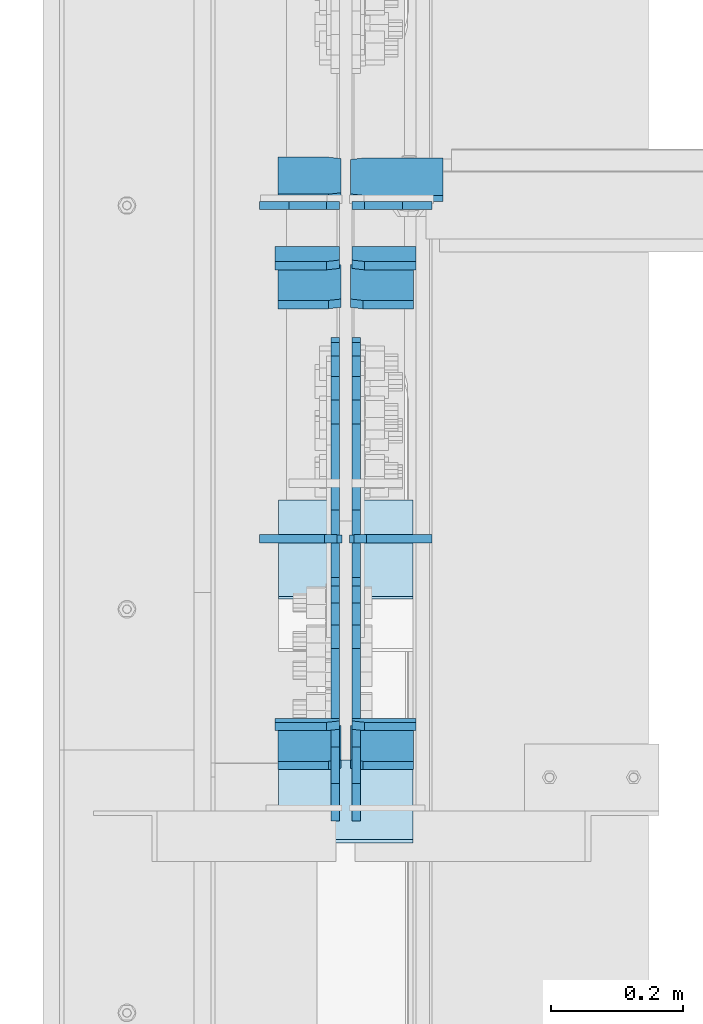
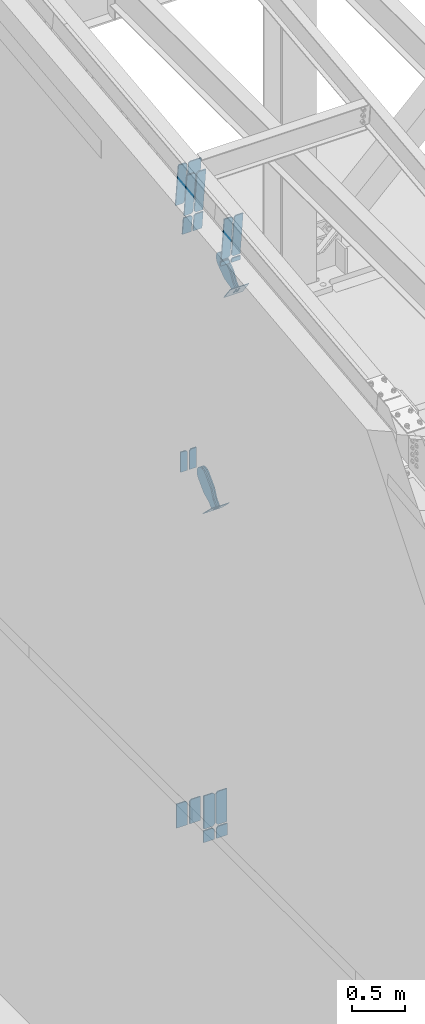
# One storey, part 992 of 1179: 24 plates, 9 elements without a shape of their own.
"""IFC2X3 building model written with IfcOpenShell, lengths in millimetres."""

from ifc_helpers import new_model, si_unit, frame, origin_with_axes, place, context, subcontext, project, spatial, faceted_brep, material, type_object, element, aggregate, save


model = new_model("IFC2X3")

# Units and contexts
model_context = context("Model", 3, precision=1e-05, world=origin_with_axes())
body_context = subcontext(model_context, "Body", "Model", "MODEL_VIEW")
ifc_project = project(units=[si_unit("LENGTHUNIT", "METRE", prefix="MILLI"), si_unit("AREAUNIT", "SQUARE_METRE"), si_unit("VOLUMEUNIT", "CUBIC_METRE"), si_unit("MASSUNIT", "GRAM", prefix="KILO"), si_unit("TIMEUNIT", "SECOND"), si_unit("PLANEANGLEUNIT", "RADIAN"), si_unit("SOLIDANGLEUNIT", "STERADIAN"), si_unit("THERMODYNAMICTEMPERATUREUNIT", "DEGREE_CELSIUS"), si_unit("LUMINOUSINTENSITYUNIT", "LUMEN")], contexts=[model_context])

# Site, building, storey
site_placement = place(None, origin_with_axes())
site = spatial("IfcSite", under=ifc_project, at=site_placement, CompositionType="ELEMENT")
building_placement = place(site_placement, origin_with_axes())
building = spatial("IfcBuilding", under=site, at=building_placement, Name="Undefined", CompositionType="ELEMENT")
storey_placement = place(building_placement, origin_with_axes())
storey = spatial("IfcBuildingStorey", under=building, at=storey_placement, Name="Undefined", CompositionType="ELEMENT", Elevation=0.0)

# Assembly, plates
assembly_1_placement = place(storey_placement, origin_with_axes())
assembly_1 = element("IfcElementAssembly", 1, at=assembly_1_placement, inside=storey, Name="BEAM", AssemblyPlace="NOTDEFINED", PredefinedType="RIGID_FRAME")
ifc_material_1 = material(Name="STEEL/A572-GR.50")
plate_type_1 = type_object("IfcPlateType", PredefinedType="NOTDEFINED")
plate_1_placement = place(assembly_1_placement, frame((534.193750000002, 15260.6053029208, 10444.0992973498), z_axis=(0.0, -0.112284087038017, 0.993676146336441), x_axis=(-1.0, 0.0, 0.0)))
plate_1 = element("IfcPlate", 2, at=plate_1_placement, type_object=plate_type_1, material=ifc_material_1, Name="PLATE", context=body_context, shape_type="Brep", body=[
    faceted_brep([(0.0, -6.34999999999854, 0.0), (0.0, -6.35000000019863, 498.474999998592), (0.0, 6.34999999979118, 498.474999998596), (0.0, 6.34999999999854, 0.0), (76.2000007629395, -6.35000000019863, 498.474999998592), (76.2000007629395, 6.34999999979118, 498.474999998596), (95.25, -6.350000000195, 479.425000761541), (95.25, 6.34999999980209, 479.425000761548), (95.25, -6.35000000000946, 19.0499992370496), (95.25, 6.34999999998399, 19.0499992370533), (76.2000007629395, -6.35000000000218, 0.0), (76.2000007629395, 6.34999999999491, 3.63797880709171e-12)], [[[0, 1, 2, 3]], [[1, 4, 5, 2]], [[4, 6, 7, 5]], [[6, 8, 9, 7]], [[8, 10, 11, 9]], [[10, 0, 3, 11]], [[5, 7, 9, 11, 3, 2]], [[10, 8, 6, 4, 1, 0]]]),
])
plate_2_placement = place(assembly_1_placement, frame((424.656250000002, 15260.6053029208, 10444.0992973498), z_axis=(0.0, -0.112284087038017, 0.993676146336441), x_axis=(-1.0, 0.0, 0.0)))
plate_2 = element("IfcPlate", 3, at=plate_2_placement, type_object=plate_type_1, material=ifc_material_1, Name="PLATE", context=body_context, shape_type="Brep", body=[
    faceted_brep([(0.0, -6.35000000000036, 19.0499999999993), (0.0, -6.350000000195, 479.425000761541), (0.0, 6.34999999980209, 479.425000761548), (0.0, 6.35000000000036, 19.0499999999993), (19.0499992370605, -6.35000000019863, 498.474999998592), (19.0499992370605, 6.34999999979118, 498.474999998596), (95.25, -6.349999999793, 498.474999998598), (95.25, 6.35000000020045, 498.474999998592), (95.25, -6.34999999999309, 1.81898940354586e-12), (95.25, 6.34999999999854, -1.81898940354586e-12), (19.0500000000002, -6.35000000000036, 0.0), (19.0500000000002, 6.35000000000036, 0.0)], [[[0, 1, 2, 3]], [[1, 4, 5, 2]], [[4, 6, 7, 5]], [[6, 8, 9, 7]], [[8, 10, 11, 9]], [[3, 11, 10, 0]], [[5, 7, 9, 11, 3, 2]], [[10, 8, 6, 4, 1, 0]]]),
])
plate_3_placement = place(assembly_1_placement, frame((534.193750000002, 14564.7196361651, 10365.4651396694), z_axis=(0.0, -0.112284087038017, 0.993676146336441), x_axis=(-1.0, 0.0, 0.0)))
plate_3 = element("IfcPlate", 4, at=plate_3_placement, type_object=plate_type_1, material=ifc_material_1, Name="PLATE", context=body_context, shape_type="Brep", body=[
    faceted_brep([(0.0, -6.34999999999854, 0.0), (0.0, -6.35000000019863, 498.474999998592), (0.0, 6.34999999979118, 498.474999998596), (0.0, 6.34999999999854, 0.0), (76.2000007629395, -6.35000000019863, 498.474999998592), (76.2000007629395, 6.34999999979118, 498.474999998596), (95.25, -6.350000000195, 479.425000761541), (95.25, 6.34999999980209, 479.425000761548), (95.25, -6.35000000000946, 19.0499992370496), (95.25, 6.34999999998399, 19.0499992370533), (76.2000007629395, -6.35000000000218, 0.0), (76.2000007629395, 6.34999999999491, 3.63797880709171e-12)], [[[0, 1, 2, 3]], [[1, 4, 5, 2]], [[4, 6, 7, 5]], [[6, 8, 9, 7]], [[8, 10, 11, 9]], [[10, 0, 3, 11]], [[5, 7, 9, 11, 3, 2]], [[10, 8, 6, 4, 1, 0]]]),
])
plate_4_placement = place(assembly_1_placement, frame((424.656250000002, 14564.7196361651, 10365.4651396694), z_axis=(0.0, -0.112284087038017, 0.993676146336441), x_axis=(-1.0, 0.0, 0.0)))
plate_4 = element("IfcPlate", 5, at=plate_4_placement, type_object=plate_type_1, material=ifc_material_1, Name="PLATE", context=body_context, shape_type="Brep", body=[
    faceted_brep([(0.0, -6.35000000000036, 19.0499999999993), (0.0, -6.350000000195, 479.425000761541), (0.0, 6.34999999980209, 479.425000761548), (0.0, 6.35000000000036, 19.0499999999993), (19.0499992370605, -6.35000000019863, 498.474999998592), (19.0499992370605, 6.34999999979118, 498.474999998596), (95.25, -6.349999999793, 498.474999998598), (95.25, 6.35000000020045, 498.474999998592), (95.25, -6.34999999999309, 1.81898940354586e-12), (95.25, 6.34999999999854, -1.81898940354586e-12), (19.0500000000002, -6.35000000000036, 0.0), (19.0500000000002, 6.35000000000036, 0.0)], [[[0, 1, 2, 3]], [[1, 4, 5, 2]], [[4, 6, 7, 5]], [[6, 8, 9, 7]], [[8, 10, 11, 9]], [[3, 11, 10, 0]], [[5, 7, 9, 11, 3, 2]], [[10, 8, 6, 4, 1, 0]]]),
])
ifc_material_2 = material(Name="STEEL/A36")
plate_5_placement = place(assembly_1_placement, frame((424.656250000002, 15421.0194659439, 10462.2258850809), z_axis=(0.0, -0.112284087038017, 0.993676146336441), x_axis=(-1.0, 0.0, 0.0)))
plate_5 = element("IfcPlate", 6, at=plate_5_placement, type_object=plate_type_1, material=ifc_material_2, Name="PLATE", context=body_context, shape_type="Brep", body=[
    faceted_brep([(0.0, -6.35000000000036, 19.0499999999993), (0.0, -6.350000000195, 479.425000761541), (0.0, 6.34999999980209, 479.425000761548), (0.0, 6.35000000000036, 19.0499999999993), (19.0499992370605, -6.35000000019863, 498.474999998592), (19.0499992370605, 6.34999999979118, 498.474999998596), (95.25, -6.349999999793, 498.474999998598), (95.25, 6.35000000020045, 498.474999998592), (95.25, -6.34999999999309, 1.81898940354586e-12), (95.25, 6.34999999999854, -1.81898940354586e-12), (19.0500000000002, -6.35000000000036, 0.0), (19.0500000000002, 6.35000000000036, 0.0)], [[[0, 1, 2, 3]], [[1, 4, 5, 2]], [[4, 6, 7, 5]], [[6, 8, 9, 7]], [[8, 10, 11, 9]], [[3, 11, 10, 0]], [[5, 7, 9, 11, 3, 2]], [[10, 8, 6, 4, 1, 0]]]),
])

assembly_2_placement = place(storey_placement, origin_with_axes())
assembly_2 = element("IfcElementAssembly", 7, at=assembly_2_placement, inside=storey, Name="BEAM", AssemblyPlace="NOTDEFINED", PredefinedType="RIGID_FRAME")
plate_type_2 = type_object("IfcPlateType", PredefinedType="NOTDEFINED")
plate_6_placement = place(assembly_2_placement, frame((558.006250000002, 14850.7648431904, 3703.6375), z_axis=(0.0, 0.0, 1.0), x_axis=(-1.0, 0.0, 0.0)))
plate_6 = element("IfcPlate", 8, at=plate_6_placement, type_object=plate_type_2, material=ifc_material_1, Name="PLATE", context=body_context, shape_type="Brep", body=[
    faceted_brep([(0.0, -6.34999999999854, 0.0), (0.0, -6.35000000000036, 377.825012207031), (0.0, 6.35000000000036, 377.825012207031), (0.0, 6.34999999999854, 0.0), (98.4250011444092, -6.35000000000036, 377.825012207031), (98.4250011444092, 6.35000000000036, 377.825012207031), (120.650001525879, -6.35000000000036, 355.600011825562), (120.650001525879, 6.35000000000036, 355.600011825562), (120.650001525879, -6.35000000000036, 22.2250003814697), (120.650001525879, 6.35000000000036, 22.2250003814697), (98.4250011444092, -6.35000000000036, 0.0), (98.4250011444092, 6.35000000000036, 0.0)], [[[0, 1, 2, 3]], [[1, 4, 5, 2]], [[4, 6, 7, 5]], [[6, 8, 9, 7]], [[8, 10, 11, 9]], [[10, 0, 3, 11]], [[5, 7, 9, 11, 3, 2]], [[10, 8, 6, 4, 1, 0]]]),
])
plate_7_placement = place(assembly_2_placement, frame((426.243750000002, 14850.7648431904, 3703.6375), z_axis=(0.0, 0.0, 1.0), x_axis=(-1.0, 0.0, 0.0)))
plate_7 = element("IfcPlate", 9, at=plate_7_placement, type_object=plate_type_2, material=ifc_material_1, Name="PLATE", context=body_context, shape_type="Brep", body=[
    faceted_brep([(0.0, -6.34999999999854, 22.2250003814697), (0.0, -6.34999999999854, 355.600011825562), (0.0, 6.34999999999854, 355.600011825562), (0.0, 6.34999999999854, 22.2250003814697), (22.2250003814697, -6.34999999999854, 377.825012207031), (22.2250003814697, 6.34999999999854, 377.825012207031), (120.650001525879, -6.34999999999854, 377.825012207031), (120.650001525879, 6.34999999999854, 377.825012207031), (120.650001525879, -6.34999999999854, 0.0), (120.650001525879, 6.34999999999854, 0.0), (22.2250003814697, -6.34999999999854, 0.0), (22.2250003814697, 6.34999999999854, 0.0)], [[[0, 1, 2, 3]], [[1, 4, 5, 2]], [[4, 6, 7, 5]], [[6, 8, 9, 7]], [[8, 10, 11, 9]], [[10, 0, 3, 11]], [[5, 7, 9, 11, 3, 2]], [[10, 8, 6, 4, 1, 0]]]),
])

# Assembly, plate
assembly_3_placement = place(storey_placement, origin_with_axes())
assembly_3 = element("IfcElementAssembly", 10, at=assembly_3_placement, inside=storey, AssemblyPlace="NOTDEFINED", PredefinedType="RIGID_FRAME")
plate_type_3 = type_object("IfcPlateType", PredefinedType="NOTDEFINED")
plate_8_placement = place(assembly_3_placement, frame((415.925000000002, 14479.1231602889, 10006.0708347596), z_axis=(0.0, -0.591856615182528, 0.806043266248581), x_axis=(0.0, 0.806043266248581, 0.591856615182528)))
plate_8 = element("IfcPlate", 11, at=plate_8_placement, type_object=plate_type_3, material=ifc_material_2, context=body_context, shape_type="Brep", body=[
    faceted_brep([(0.0, -6.34999999999854, 0.0), (-8.18545231595635e-11, -6.34999999999854, 91.5986124346418), (-8.18545231595635e-11, 6.34999999999854, 91.5986124346418), (0.0, 6.34999999999854, 0.0), (69.8500000000859, -6.35000000000002, 91.598612434588), (69.8500000000859, 6.35000000000002, 91.598612434588), (171.450000000154, -6.35000000000002, 136.286806216977), (171.450000000154, 6.35000000000002, 136.286806216977), (316.534985847466, -6.35000000000002, 136.286806216974), (316.534985847466, 6.35000000000002, 136.286806216974), (351.163054101464, -6.35000000000002, 129.398855182781), (351.163054101464, 6.35000000000002, 129.398855182781), (380.519312868008, -6.35000000000002, 109.783630185736), (380.519312868008, 6.35000000000002, 109.783630185736), (400.134537865033, -6.35000000000002, 80.427371419183), (400.134537865033, 6.35000000000002, 80.427371419183), (407.022488899202, -6.35000000000002, 45.799309269273), (407.022488899202, 6.35000000000002, 45.799309269273), (400.134537865, -6.35000000000002, 11.1712410153075), (400.134537865, 6.35000000000002, 11.1712410153075), (380.519312867968, -6.35000000000002, -18.1850177512089), (380.519312867968, 6.35000000000002, -18.1850177512089), (351.163054101435, -6.35000000000002, -37.8002427482235), (351.163054101435, 6.35000000000002, -37.8002427482235), (316.534988899111, -6.35000000000002, -44.6881937824029), (316.534988899111, 6.35000000000002, -44.6881937824029), (171.450000000041, -6.35000000000002, -44.6881937823993), (171.450000000041, 6.35000000000002, -44.6881937823993), (69.849999425729, -6.34999999999854, 0.0), (69.849999425729, 6.34999999999854, 0.0)], [[[0, 1, 2, 3]], [[1, 4, 5, 2]], [[4, 6, 7, 5]], [[6, 8, 9, 7]], [[8, 10, 11, 9]], [[10, 12, 13, 11]], [[12, 14, 15, 13]], [[14, 16, 17, 15]], [[16, 18, 19, 17]], [[18, 20, 21, 19]], [[20, 22, 23, 21]], [[22, 24, 25, 23]], [[24, 26, 27, 25]], [[26, 28, 29, 27]], [[28, 0, 3, 29]], [[5, 7, 9, 11, 13, 15, 17, 19, 21, 23, 25, 27, 29, 3, 2]], [[28, 26, 24, 22, 20, 18, 16, 14, 12, 10, 8, 6, 4, 1, 0]]]),
])
aggregate(assembly_3, [plate_8])

assembly_4_placement = place(storey_placement, origin_with_axes())
assembly_4 = element("IfcElementAssembly", 12, at=assembly_4_placement, inside=storey, AssemblyPlace="NOTDEFINED", PredefinedType="RIGID_FRAME")
plate_9_placement = place(assembly_4_placement, frame((447.675000000002, 14479.1231602889, 10006.0708347596), z_axis=(0.0, -0.591856615182528, 0.806043266248581), x_axis=(0.0, 0.806043266248581, 0.591856615182528)))
plate_9 = element("IfcPlate", 13, at=plate_9_placement, type_object=plate_type_3, material=ifc_material_2, context=body_context, shape_type="Brep", body=[
    faceted_brep([(0.0, -6.34999999999854, 0.0), (-8.18545231595635e-11, -6.34999999999854, 91.5986124346418), (-8.18545231595635e-11, 6.34999999999854, 91.5986124346418), (0.0, 6.34999999999854, 0.0), (69.8500000000859, -6.35000000000002, 91.598612434588), (69.8500000000859, 6.35000000000002, 91.598612434588), (171.450000000154, -6.35000000000002, 136.286806216977), (171.450000000154, 6.35000000000002, 136.286806216977), (316.534985847466, -6.35000000000002, 136.286806216974), (316.534985847466, 6.35000000000002, 136.286806216974), (351.163054101464, -6.35000000000002, 129.398855182781), (351.163054101464, 6.35000000000002, 129.398855182781), (380.519312868008, -6.35000000000002, 109.783630185736), (380.519312868008, 6.35000000000002, 109.783630185736), (400.134537865033, -6.35000000000002, 80.427371419183), (400.134537865033, 6.35000000000002, 80.427371419183), (407.022488899202, -6.35000000000002, 45.799309269273), (407.022488899202, 6.35000000000002, 45.799309269273), (400.134537865, -6.35000000000002, 11.1712410153075), (400.134537865, 6.35000000000002, 11.1712410153075), (380.519312867968, -6.35000000000002, -18.1850177512089), (380.519312867968, 6.35000000000002, -18.1850177512089), (351.163054101435, -6.35000000000002, -37.8002427482235), (351.163054101435, 6.35000000000002, -37.8002427482235), (316.534988899111, -6.35000000000002, -44.6881937824029), (316.534988899111, 6.35000000000002, -44.6881937824029), (171.450000000041, -6.35000000000002, -44.6881937823993), (171.450000000041, 6.35000000000002, -44.6881937823993), (69.849999425729, -6.34999999999854, 0.0), (69.849999425729, 6.34999999999854, 0.0)], [[[0, 1, 2, 3]], [[1, 4, 5, 2]], [[4, 6, 7, 5]], [[6, 8, 9, 7]], [[8, 10, 11, 9]], [[10, 12, 13, 11]], [[12, 14, 15, 13]], [[14, 16, 17, 15]], [[16, 18, 19, 17]], [[18, 20, 21, 19]], [[20, 22, 23, 21]], [[22, 24, 25, 23]], [[24, 26, 27, 25]], [[26, 28, 29, 27]], [[28, 0, 3, 29]], [[5, 7, 9, 11, 13, 15, 17, 19, 21, 23, 25, 27, 29, 3, 2]], [[28, 26, 24, 22, 20, 18, 16, 14, 12, 10, 8, 6, 4, 1, 0]]]),
])
aggregate(assembly_4, [plate_9])

assembly_5_placement = place(storey_placement, origin_with_axes())
assembly_5 = element("IfcElementAssembly", 14, at=assembly_5_placement, inside=storey, Name="Plate", AssemblyPlace="NOTDEFINED", PredefinedType="RIGID_FRAME")
plate_type_4 = type_object("IfcPlateType", PredefinedType="NOTDEFINED")
plate_10_placement = place(assembly_5_placement, frame((533.400000000002, 14514.7083574087, 9962.97220603954), z_axis=(0.0, -0.591856615182528, 0.806043266248581), x_axis=(-1.0, 0.0, 0.0)))
plate_10 = element("IfcPlate", 15, at=plate_10_placement, type_object=plate_type_4, material=ifc_material_2, Name="Plate", context=body_context, shape_type="Brep", body=[
    faceted_brep([(0.0, -3.17500000000109, 0.0), (0.0, -3.17500000000291, 203.200000000368), (0.0, 3.17499999998836, 203.200000000361), (0.0, 3.17500000000109, 7.27595761418343e-12), (203.199999999997, -3.17500000000291, 203.200000000368), (203.199999999997, 3.17499999998836, 203.200000000361), (203.199999999997, -3.17499999999927, 3.63797880709171e-12), (203.199999999997, 3.17499999999382, -3.63797880709171e-12)], [[[0, 1, 2, 3]], [[1, 4, 5, 2]], [[4, 6, 7, 5]], [[6, 0, 3, 7]], [[5, 7, 3, 2]], [[6, 4, 1, 0]]]),
])
aggregate(assembly_5, [plate_10])

assembly_6_placement = place(storey_placement, origin_with_axes())
assembly_6 = element("IfcElementAssembly", 16, at=assembly_6_placement, inside=storey, Name="Plate", AssemblyPlace="NOTDEFINED", PredefinedType="RIGID_FRAME")
plate_11_placement = place(assembly_6_placement, frame((533.400000000002, 14907.464743827, 7258.01555805028), z_axis=(0.0, -0.715642339037758, 0.698466923036852), x_axis=(-1.0, 0.0, 0.0)))
plate_11 = element("IfcPlate", 17, at=plate_11_placement, type_object=plate_type_4, material=ifc_material_2, Name="Plate", context=body_context, shape_type="Brep", body=[
    faceted_brep([(0.0, -3.17500000000109, 0.0), (0.0, -3.17500000000291, 203.200000000368), (0.0, 3.17499999998836, 203.200000000361), (0.0, 3.17500000000109, 7.27595761418343e-12), (203.199999999997, -3.17500000000291, 203.200000000368), (203.199999999997, 3.17499999998836, 203.200000000361), (203.199999999997, -3.17499999999927, 3.63797880709171e-12), (203.199999999997, 3.17499999999382, -3.63797880709171e-12)], [[[0, 1, 2, 3]], [[1, 4, 5, 2]], [[4, 6, 7, 5]], [[6, 0, 3, 7]], [[5, 7, 3, 2]], [[6, 4, 1, 0]]]),
])
aggregate(assembly_6, [plate_11])

# Plate
plate_type_5 = type_object("IfcPlateType", PredefinedType="NOTDEFINED")
plate_12_placement = place(assembly_1_placement, frame((438.943750000002, 15365.048655516, 10957.5486021073), z_axis=(1.0, 0.0, 0.0), x_axis=(0.0, 0.112284087038014, -0.993676146336441)))
plate_12 = element("IfcPlate", 18, at=plate_12_placement, type_object=plate_type_5, material=ifc_material_2, Name="PLATE", context=body_context, shape_type="Brep", body=[
    faceted_brep([(-1.81898940354586e-12, -4.76249999999345, 17.4624996185303), (0.0, -4.76249999999982, 139.699999999997), (0.0, 4.76249999999982, 139.699999999997), (1.81898940354586e-12, 4.76250000000073, 17.4624996185303), (498.474999999158, -4.76250000020082, 139.7), (498.474999999162, 4.762499999797, 139.7), (498.474999999158, -4.76250000020082, 17.4624996185303), (498.474999999162, 4.762499999797, 17.4624996185303), (481.012500380637, -4.7625000001899, 0.0), (481.012500380642, 4.76249999980791, 0.0), (17.4624996185157, -4.76250000000073, 0.0), (17.4624996185212, 4.76249999999345, 0.0)], [[[0, 1, 2, 3]], [[1, 4, 5, 2]], [[4, 6, 7, 5]], [[6, 8, 9, 7]], [[8, 10, 11, 9]], [[10, 0, 3, 11]], [[5, 7, 9, 11, 3, 2]], [[10, 8, 6, 4, 1, 0]]]),
])

plate_type_6 = type_object("IfcPlateType", PredefinedType="NOTDEFINED")
plate_13_placement = place(assembly_1_placement, frame((422.275000000001, 14567.5716519045, 10340.2257661847), z_axis=(-1.0, 0.0, 0.0), x_axis=(0.0, 0.112284087038014, -0.993676146336441)))
plate_13 = element("IfcPlate", 19, at=plate_13_placement, type_object=plate_type_6, material=ifc_material_1, Name="PLATE", context=body_context, shape_type="Brep", body=[
    faceted_brep([(0.0, 6.35000000000036, 19.0499999999993), (19.0500000000002, 6.35000000000036, 0.0), (19.0500000000002, -6.35000000000036, 0.0), (0.0, -6.35000000000036, 19.0499999999993), (0.0, -6.35000000000036, 96.8374999999978), (0.0, 6.35000000000036, 96.8374999999978), (50.799999999721, -6.34999999997308, 96.8375), (50.7999999997155, 6.35000000001673, 96.8375), (50.799999999721, -6.34999999997308, 0.0), (50.7999999997155, 6.35000000001673, 0.0)], [[[0, 1, 2, 3]], [[4, 5, 0, 3]], [[4, 6, 7, 5]], [[6, 8, 9, 7]], [[9, 8, 2, 1]], [[5, 7, 9, 1, 0]], [[8, 6, 4, 3, 2]]]),
])

plate_14_placement = place(assembly_1_placement, frame((441.325000000003, 14567.5716519045, 10340.2257661847), z_axis=(1.0, 0.0, 0.0), x_axis=(0.0, 0.112284087038014, -0.993676146336441)))
plate_14 = element("IfcPlate", 20, at=plate_14_placement, type_object=plate_type_6, material=ifc_material_1, Name="PLATE", context=body_context, shape_type="Brep", body=[
    faceted_brep([(0.0, 6.35000000000036, 19.0499999999993), (19.0500000000002, 6.35000000000036, 0.0), (19.0500000000002, -6.35000000000036, 0.0), (0.0, -6.35000000000036, 19.0499999999993), (0.0, -6.35000000000036, 96.8374999999978), (0.0, 6.35000000000036, 96.8374999999978), (50.799999999721, -6.34999999997308, 96.8375), (50.7999999997155, 6.35000000001673, 96.8375), (50.799999999721, -6.34999999997308, 0.0), (50.7999999997155, 6.35000000001673, 0.0)], [[[0, 1, 2, 3]], [[4, 5, 0, 3]], [[4, 6, 7, 5]], [[6, 8, 9, 7]], [[9, 8, 2, 1]], [[5, 7, 9, 1, 0]], [[8, 6, 4, 3, 2]]]),
])

plate_type_7 = type_object("IfcPlateType", PredefinedType="NOTDEFINED")
plate_15_placement = place(assembly_1_placement, frame((422.275000000001, 15263.4524175231, 10418.8593700433), z_axis=(-1.0, 0.0, 0.0), x_axis=(0.0, 0.112284087038014, -0.993676146336441)))
plate_15 = element("IfcPlate", 21, at=plate_15_placement, type_object=plate_type_7, material=ifc_material_1, Name="PLATE", context=body_context, shape_type="Brep", body=[
    faceted_brep([(0.0, 6.35000000000036, 19.0499999999993), (19.0500000000002, 6.35000000000036, 0.0), (19.0500000000002, -6.35000000000036, 0.0), (0.0, -6.35000000000036, 19.0499999999993), (0.0, -6.35000000000036, 96.8374999999978), (0.0, 6.35000000000036, 96.8374999999978), (201.348908600263, -6.34999999991487, 96.8374999999978), (201.348908600257, 6.35000000007858, 96.8374999999978), (201.348908600263, -6.34999999991487, 0.0), (201.348908600257, 6.35000000007858, 0.0)], [[[0, 1, 2, 3]], [[4, 5, 0, 3]], [[4, 6, 7, 5]], [[6, 8, 9, 7]], [[9, 8, 2, 1]], [[5, 7, 9, 1, 0]], [[8, 6, 4, 3, 2]]]),
])

plate_16_placement = place(assembly_1_placement, frame((441.325000000003, 15263.4524175231, 10418.8593700433), z_axis=(1.0, 0.0, 0.0), x_axis=(0.0, 0.112284087038014, -0.993676146336441)))
plate_16 = element("IfcPlate", 22, at=plate_16_placement, type_object=plate_type_7, material=ifc_material_1, Name="PLATE", context=body_context, shape_type="Brep", body=[
    faceted_brep([(0.0, 6.35000000000036, 19.0499999999993), (19.0500000000002, 6.35000000000036, 0.0), (19.0500000000002, -6.35000000000036, 0.0), (0.0, -6.35000000000036, 19.0499999999993), (0.0, -6.35000000000036, 96.8374999999978), (0.0, 6.35000000000036, 96.8374999999978), (201.348908600263, -6.34999999991487, 96.8374999999978), (201.348908600257, 6.35000000007858, 96.8374999999978), (201.348908600263, -6.34999999991487, 0.0), (201.348908600257, 6.35000000007858, 0.0)], [[[0, 1, 2, 3]], [[4, 5, 0, 3]], [[4, 6, 7, 5]], [[6, 8, 9, 7]], [[9, 8, 2, 1]], [[5, 7, 9, 1, 0]], [[8, 6, 4, 3, 2]]]),
])

aggregate(assembly_1, [plate_1, plate_2, plate_3, plate_4, plate_5, plate_12, plate_13, plate_14, plate_15, plate_16])

plate_type_8 = type_object("IfcPlateType", PredefinedType="NOTDEFINED")
plate_17_placement = place(assembly_2_placement, frame((419.100000000002, 14850.8102579444, 3549.97993849189), z_axis=(-1.0, 0.0, 0.0), x_axis=(0.0, 0.0, 1.0)))
plate_17 = element("IfcPlate", 23, at=plate_17_placement, type_object=plate_type_8, material=ifc_material_1, Name="PLATE", context=body_context, shape_type="Brep", body=[
    faceted_brep([(0.0, -6.34999999999854, 0.0), (0.0, -6.35000000000036, 117.474999999999), (0.0, 6.35000000000036, 117.474999999999), (0.0, 6.34999999999854, 0.0), (133.020061565272, -6.35000000000036, 117.474999999999), (133.020061565272, 6.35000000000036, 117.474999999999), (133.020061565272, -6.35000000000036, 19.0499992370605), (133.020061565272, 6.35000000000036, 19.0499992370605), (113.970062328212, -6.35000000000036, 0.0), (113.970062328212, 6.35000000000036, 0.0)], [[[0, 1, 2, 3]], [[1, 4, 5, 2]], [[4, 6, 7, 5]], [[6, 8, 9, 7]], [[8, 0, 3, 9]], [[5, 7, 9, 3, 2]], [[8, 6, 4, 1, 0]]]),
])

plate_18_placement = place(assembly_2_placement, frame((444.500000000002, 14850.8102579444, 3549.97993849189), z_axis=(1.0, 0.0, 0.0), x_axis=(0.0, 0.0, 1.0)))
plate_18 = element("IfcPlate", 24, at=plate_18_placement, type_object=plate_type_8, material=ifc_material_1, Name="PLATE", context=body_context, shape_type="Brep", body=[
    faceted_brep([(0.0, -6.34999999999854, 0.0), (0.0, -6.35000000000036, 117.474999999999), (0.0, 6.35000000000036, 117.474999999999), (0.0, 6.34999999999854, 0.0), (133.020061565272, -6.35000000000036, 117.474999999999), (133.020061565272, 6.35000000000036, 117.474999999999), (133.020061565272, -6.35000000000036, 19.0499992370605), (133.020061565272, 6.35000000000036, 19.0499992370605), (113.970062328212, -6.35000000000036, 0.0), (113.970062328212, 6.35000000000036, 0.0)], [[[0, 1, 2, 3]], [[1, 4, 5, 2]], [[4, 6, 7, 5]], [[6, 8, 9, 7]], [[8, 0, 3, 9]], [[5, 7, 9, 3, 2]], [[8, 6, 4, 1, 0]]]),
])

plate_19_placement = place(assembly_2_placement, frame((419.100000000002, 15354.3, 3409.84913740723), z_axis=(-1.0, 0.0, 0.0), x_axis=(0.0, 0.0, 1.0)))
plate_19 = element("IfcPlate", 25, at=plate_19_placement, type_object=plate_type_8, material=ifc_material_1, Name="PLATE", context=body_context, shape_type="Brep", body=[
    faceted_brep([(0.0, -6.34999999999854, 0.0), (0.0, -6.35000000000036, 117.474999999999), (0.0, 6.35000000000036, 117.474999999999), (0.0, 6.34999999999854, 0.0), (273.150862592773, -6.35000000000036, 117.474999999999), (273.150862592773, 6.35000000000036, 117.474999999999), (273.150862592773, -6.35000000000036, 19.0499992370605), (273.150862592773, 6.35000000000036, 19.0499992370605), (254.100863355713, -6.35000000000036, 0.0), (254.100863355713, 6.35000000000036, 0.0)], [[[0, 1, 2, 3]], [[1, 4, 5, 2]], [[4, 6, 7, 5]], [[6, 8, 9, 7]], [[8, 0, 3, 9]], [[5, 7, 9, 3, 2]], [[8, 6, 4, 1, 0]]]),
])

plate_20_placement = place(assembly_2_placement, frame((444.500000000002, 15354.3, 3409.84913740723), z_axis=(1.0, 0.0, 0.0), x_axis=(0.0, 0.0, 1.0)))
plate_20 = element("IfcPlate", 26, at=plate_20_placement, type_object=plate_type_8, material=ifc_material_1, Name="PLATE", context=body_context, shape_type="Brep", body=[
    faceted_brep([(0.0, -6.34999999999854, 0.0), (0.0, -6.35000000000036, 117.474999999999), (0.0, 6.35000000000036, 117.474999999999), (0.0, 6.34999999999854, 0.0), (273.150862592773, -6.35000000000036, 117.474999999999), (273.150862592773, 6.35000000000036, 117.474999999999), (273.150862592773, -6.35000000000036, 19.0499992370605), (273.150862592773, 6.35000000000036, 19.0499992370605), (254.100863355713, -6.35000000000036, 0.0), (254.100863355713, 6.35000000000036, 0.0)], [[[0, 1, 2, 3]], [[1, 4, 5, 2]], [[4, 6, 7, 5]], [[6, 8, 9, 7]], [[8, 0, 3, 9]], [[5, 7, 9, 3, 2]], [[8, 6, 4, 1, 0]]]),
])

aggregate(assembly_2, [plate_6, plate_7, plate_17, plate_18, plate_19, plate_20])

# Assembly, plate
assembly_7_placement = place(storey_placement, origin_with_axes())
assembly_7 = element("IfcElementAssembly", 27, at=assembly_7_placement, inside=storey, AssemblyPlace="NOTDEFINED", PredefinedType="RIGID_FRAME")
plate_type_9 = type_object("IfcPlateType", PredefinedType="NOTDEFINED")
plate_21_placement = place(assembly_7_placement, frame((415.925000000002, 14872.679992843, 7287.52890129055), z_axis=(0.0, -0.715642339037758, 0.698466923036852), x_axis=(0.0, 0.698466923036852, 0.715642339037758)))
plate_21 = element("IfcPlate", 28, at=plate_21_placement, type_object=plate_type_9, material=ifc_material_2, context=body_context, shape_type="Brep", body=[
    faceted_brep([(0.0, -6.34999999999854, 0.0), (-4.35647962149233e-10, -6.34999999999854, 112.184930806416), (-4.35647962149233e-10, 6.34999999999854, 112.184930806416), (0.0, 6.34999999999854, 0.0), (82.5499999996491, -6.34999999999854, 112.184930806461), (82.5499999996491, 6.34999999999854, 112.184930806461), (184.149999999618, -6.34999999999854, 149.75496540347), (184.149999999618, 6.34999999999854, 149.75496540347), (327.919242323534, -6.34999999999854, 149.754965403559), (327.919242323534, 6.34999999999854, 149.754965403559), (363.762328723451, -6.34999999999854, 142.625332233587), (363.762328723451, 6.34999999999854, 142.625332233587), (394.148630137406, -6.34999999999854, 122.321854743475), (394.148630137406, 6.34999999999854, 122.321854743475), (414.452107627645, -6.34999999999854, 91.9355533295929), (414.452107627645, 6.34999999999854, 91.9355533295929), (421.581740797776, -6.34999999999854, 56.0924638777396), (421.581740797776, 6.34999999999854, 56.0924638777396), (414.452107627878, -6.34999999999854, 20.2493774776722), (414.452107627878, 6.34999999999854, 20.2493774776722), (394.14863013775, -6.34999999999854, -10.1369239363994), (394.14863013775, 6.34999999999854, -10.1369239363994), (363.762328723789, -6.34999999999854, -30.4404014266784), (363.762328723789, 6.34999999999854, -30.4404014266784), (327.919240798041, -6.34999999999854, -37.570034596738), (327.919240798041, 6.34999999999854, -37.570034596738), (184.150000000338, -6.34999999999854, -37.5700345968289), (184.150000000338, 6.34999999999854, -37.5700345968289), (82.550000000203, -6.34999999999854, 1.2732925824821e-10), (82.550000000203, 6.34999999999854, 1.2732925824821e-10)], [[[0, 1, 2, 3]], [[1, 4, 5, 2]], [[4, 6, 7, 5]], [[6, 8, 9, 7]], [[8, 10, 11, 9]], [[10, 12, 13, 11]], [[12, 14, 15, 13]], [[14, 16, 17, 15]], [[16, 18, 19, 17]], [[18, 20, 21, 19]], [[20, 22, 23, 21]], [[22, 24, 25, 23]], [[24, 26, 27, 25]], [[26, 28, 29, 27]], [[28, 0, 3, 29]], [[5, 7, 9, 11, 13, 15, 17, 19, 21, 23, 25, 27, 29, 3, 2]], [[28, 26, 24, 22, 20, 18, 16, 14, 12, 10, 8, 6, 4, 1, 0]]]),
])
aggregate(assembly_7, [plate_21])

assembly_8_placement = place(storey_placement, origin_with_axes())
assembly_8 = element("IfcElementAssembly", 29, at=assembly_8_placement, inside=storey, AssemblyPlace="NOTDEFINED", PredefinedType="RIGID_FRAME")
plate_22_placement = place(assembly_8_placement, frame((447.675000000002, 14872.679992843, 7287.52890129055), z_axis=(0.0, -0.715642339037758, 0.698466923036852), x_axis=(0.0, 0.698466923036852, 0.715642339037758)))
plate_22 = element("IfcPlate", 30, at=plate_22_placement, type_object=plate_type_9, material=ifc_material_2, context=body_context, shape_type="Brep", body=[
    faceted_brep([(0.0, -6.34999999999854, 0.0), (-4.35647962149233e-10, -6.34999999999854, 112.184930806416), (-4.35647962149233e-10, 6.34999999999854, 112.184930806416), (0.0, 6.34999999999854, 0.0), (82.5499999996491, -6.34999999999854, 112.184930806461), (82.5499999996491, 6.34999999999854, 112.184930806461), (184.149999999618, -6.34999999999854, 149.75496540347), (184.149999999618, 6.34999999999854, 149.75496540347), (327.919242323534, -6.34999999999854, 149.754965403559), (327.919242323534, 6.34999999999854, 149.754965403559), (363.762328723451, -6.34999999999854, 142.625332233587), (363.762328723451, 6.34999999999854, 142.625332233587), (394.148630137406, -6.34999999999854, 122.321854743475), (394.148630137406, 6.34999999999854, 122.321854743475), (414.452107627645, -6.34999999999854, 91.9355533295929), (414.452107627645, 6.34999999999854, 91.9355533295929), (421.581740797776, -6.34999999999854, 56.0924638777396), (421.581740797776, 6.34999999999854, 56.0924638777396), (414.452107627878, -6.34999999999854, 20.2493774776722), (414.452107627878, 6.34999999999854, 20.2493774776722), (394.14863013775, -6.34999999999854, -10.1369239363994), (394.14863013775, 6.34999999999854, -10.1369239363994), (363.762328723789, -6.34999999999854, -30.4404014266784), (363.762328723789, 6.34999999999854, -30.4404014266784), (327.919240798041, -6.34999999999854, -37.570034596738), (327.919240798041, 6.34999999999854, -37.570034596738), (184.150000000338, -6.34999999999854, -37.5700345968289), (184.150000000338, 6.34999999999854, -37.5700345968289), (82.550000000203, -6.34999999999854, 1.2732925824821e-10), (82.550000000203, 6.34999999999854, 1.2732925824821e-10)], [[[0, 1, 2, 3]], [[1, 4, 5, 2]], [[4, 6, 7, 5]], [[6, 8, 9, 7]], [[8, 10, 11, 9]], [[10, 12, 13, 11]], [[12, 14, 15, 13]], [[14, 16, 17, 15]], [[16, 18, 19, 17]], [[18, 20, 21, 19]], [[20, 22, 23, 21]], [[22, 24, 25, 23]], [[24, 26, 27, 25]], [[26, 28, 29, 27]], [[28, 0, 3, 29]], [[5, 7, 9, 11, 13, 15, 17, 19, 21, 23, 25, 27, 29, 3, 2]], [[28, 26, 24, 22, 20, 18, 16, 14, 12, 10, 8, 6, 4, 1, 0]]]),
])
aggregate(assembly_8, [plate_22])

# Assembly, plates
assembly_9_placement = place(storey_placement, origin_with_axes())
assembly_9 = element("IfcElementAssembly", 31, at=assembly_9_placement, inside=storey, Name="BEAM", AssemblyPlace="NOTDEFINED", PredefinedType="RIGID_FRAME")
plate_type_10 = type_object("IfcPlateType", PredefinedType="NOTDEFINED")
plate_23_placement = place(assembly_9_placement, frame((422.275000000003, 15354.3, 7683.5), z_axis=(-1.0, 0.0, 0.0), x_axis=(0.0, 0.0, -1.0)))
plate_23 = element("IfcPlate", 32, at=plate_23_placement, type_object=plate_type_10, material=ifc_material_1, Name="PLATE", context=body_context, shape_type="Brep", body=[
    faceted_brep([(0.0, 6.35000000000036, 19.0499999999993), (19.0500000000002, 6.35000000000036, 0.0), (19.0500000000002, -6.35000000000036, 0.0), (0.0, -6.35000000000036, 19.0499999999993), (0.0, -6.35000000000036, 76.2000000000044), (0.0, 6.35000000000036, 76.2000000000044), (228.599999999999, -6.35000000000036, 76.2000000000007), (228.599999999991, 6.35000000000036, 76.1999999999971), (228.600000000002, -6.34999999999854, 0.0), (228.600000000002, 6.34999999999854, 0.0)], [[[0, 1, 2, 3]], [[4, 5, 0, 3]], [[4, 6, 7, 5]], [[6, 8, 9, 7]], [[9, 8, 2, 1]], [[5, 7, 9, 1, 0]], [[8, 6, 4, 3, 2]]]),
])
plate_24_placement = place(assembly_9_placement, frame((441.325000000003, 15354.3, 7683.5), z_axis=(1.0, 0.0, 0.0), x_axis=(0.0, 0.0, -1.0)))
plate_24 = element("IfcPlate", 33, at=plate_24_placement, type_object=plate_type_10, material=ifc_material_1, Name="PLATE", context=body_context, shape_type="Brep", body=[
    faceted_brep([(0.0, 6.35000000000036, 19.0499999999993), (19.0500000000002, 6.35000000000036, 0.0), (19.0500000000002, -6.35000000000036, 0.0), (0.0, -6.35000000000036, 19.0499999999993), (0.0, -6.35000000000036, 76.2000000000044), (0.0, 6.35000000000036, 76.2000000000044), (228.599999999999, -6.35000000000036, 76.2000000000007), (228.599999999991, 6.35000000000036, 76.1999999999971), (228.600000000002, -6.34999999999854, 0.0), (228.600000000002, 6.34999999999854, 0.0)], [[[0, 1, 2, 3]], [[4, 5, 0, 3]], [[4, 6, 7, 5]], [[6, 8, 9, 7]], [[9, 8, 2, 1]], [[5, 7, 9, 1, 0]], [[8, 6, 4, 3, 2]]]),
])
aggregate(assembly_9, [plate_23, plate_24])

save(model, "model.ifc")
